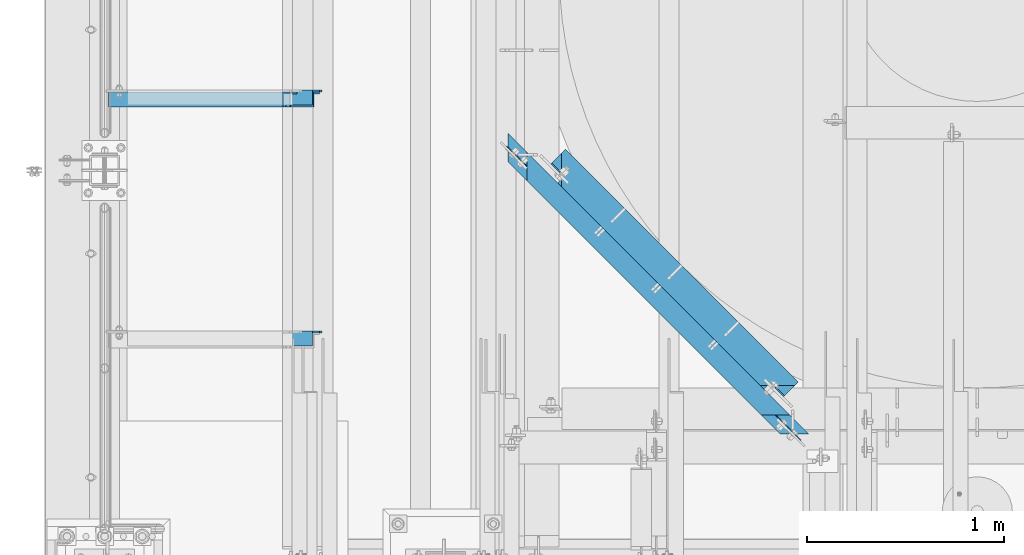
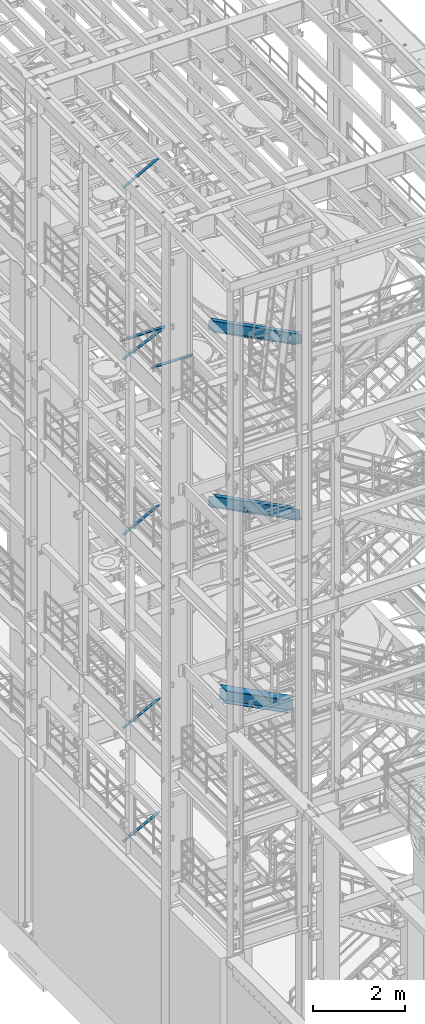
# One storey, part 971 of 1876: 5 beams, 5 members, 10 elements without a shape of their own.
"""IFC2X3 building model written with IfcOpenShell, lengths in millimetres."""

from ifc_helpers import new_model, si_unit, frame, origin_with_axes, place, context, subcontext, project, spatial, faceted_brep, material, type_object, element, aggregate, save


model = new_model("IFC2X3")

# Units and contexts
model_context = context("Model", 3, precision=1e-05, world=origin_with_axes())
body_context = subcontext(model_context, "Body", "Model", "MODEL_VIEW")
ifc_project = project(units=[si_unit("LENGTHUNIT", "METRE", prefix="MILLI"), si_unit("AREAUNIT", "SQUARE_METRE"), si_unit("VOLUMEUNIT", "CUBIC_METRE"), si_unit("MASSUNIT", "GRAM", prefix="KILO"), si_unit("TIMEUNIT", "SECOND"), si_unit("PLANEANGLEUNIT", "RADIAN"), si_unit("SOLIDANGLEUNIT", "STERADIAN"), si_unit("THERMODYNAMICTEMPERATUREUNIT", "DEGREE_CELSIUS"), si_unit("LUMINOUSINTENSITYUNIT", "LUMEN")], contexts=[model_context])

# Site, building, storey
site_placement = place(None, origin_with_axes())
site = spatial("IfcSite", under=ifc_project, at=site_placement, CompositionType="ELEMENT")
building_placement = place(site_placement, origin_with_axes())
building = spatial("IfcBuilding", under=site, at=building_placement, Name="Undefined", CompositionType="ELEMENT")
storey_placement = place(building_placement, origin_with_axes())
storey = spatial("IfcBuildingStorey", under=building, at=storey_placement, Name="Undefined", CompositionType="ELEMENT", Elevation=0.0)

# Assembly, member
assembly_1_placement = place(storey_placement, origin_with_axes())
assembly_1 = element("IfcElementAssembly", 1, at=assembly_1_placement, inside=storey, AssemblyPlace="NOTDEFINED", PredefinedType="RIGID_FRAME")
ifc_material_1 = material(Name="STEEL/A36")
member_type = type_object("IfcMemberType", Name="L3X3X3/8", PredefinedType="NOTDEFINED")
member_1_placement = place(assembly_1_placement, frame((15.9156353109856, -2181.225, 17440.5834930797), z_axis=(0.0, -1.0, 0.0), x_axis=(0.908569735485921, 0.0, 0.417733211223436)))
member_1 = element("IfcMember", 2, at=member_1_placement, type_object=member_type, material=ifc_material_1, ObjectType="L3X3X3/8", context=body_context, shape_type="Brep", body=[
    faceted_brep([(21.8406460853457, 38.0999999999894, -38.0999999999999), (21.8406460853457, 38.0999999999894, 38.0999999999999), (1162.88335939537, 38.0999999996566, 38.0999999999999), (1162.88335939537, 38.0999999996566, -38.0999999999999), (21.8406460853494, 28.5749999999916, 38.0999999999999), (1162.88335939538, 28.5749999996551, 38.0999999999999), (21.8406460853494, 28.5749999999916, -28.5749999999998), (1162.88335939538, 28.5749999996551, -28.5749999999998), (21.8406460853721, -38.1000000000022, -28.5749999999998), (1162.8833593954, -38.1000000003332, -28.5749999999998), (21.8406460853721, -38.1000000000022, -38.0999999999999), (1162.8833593954, -38.1000000003332, -38.0999999999999)], [[[0, 1, 2, 3]], [[1, 4, 5, 2]], [[4, 6, 7, 5]], [[6, 8, 9, 7]], [[8, 10, 11, 9]], [[10, 0, 3, 11]], [[5, 7, 9, 11, 3, 2]], [[10, 8, 6, 4, 1, 0]]]),
])
aggregate(assembly_1, [member_1])

assembly_2_placement = place(storey_placement, origin_with_axes())
assembly_2 = element("IfcElementAssembly", 3, at=assembly_2_placement, inside=storey, AssemblyPlace="NOTDEFINED", PredefinedType="RIGID_FRAME")
member_2_placement = place(assembly_2_placement, frame((17.8851909639217, -2181.225, 7599.05883178481), z_axis=(0.0, -1.0, 0.0), x_axis=(0.882970975303512, 0.0, 0.469427584161354)))
member_2 = element("IfcMember", 4, at=member_2_placement, type_object=member_type, material=ifc_material_1, ObjectType="L3X3X3/8", context=body_context, shape_type="Brep", body=[
    faceted_brep([(22.4738417769599, 38.1000000000004, -38.0999999999999), (22.4738417769599, 38.1000000000004, 38.0999999999999), (1061.87831940918, 38.0999999998248, 38.0999999999999), (1061.87831940918, 38.0999999998248, -38.0999999999999), (22.4738417769613, 28.5749999999998, 38.0999999999999), (1061.87831940918, 28.5749999998243, 38.0999999999999), (22.4738417769613, 28.5749999999998, -28.5749999999998), (1061.87831940918, 28.5749999998243, -28.5749999999998), (22.4738417769699, -38.100000000004, -28.5749999999998), (1061.87831940919, -38.1000000001804, -28.5749999999998), (22.4738417769699, -38.100000000004, -38.0999999999999), (1061.87831940919, -38.1000000001804, -38.0999999999999)], [[[0, 1, 2, 3]], [[1, 4, 5, 2]], [[4, 6, 7, 5]], [[6, 8, 9, 7]], [[8, 10, 11, 9]], [[10, 0, 3, 11]], [[5, 7, 9, 11, 3, 2]], [[10, 8, 6, 4, 1, 0]]]),
])
aggregate(assembly_2, [member_2])

assembly_3_placement = place(storey_placement, origin_with_axes())
assembly_3 = element("IfcElementAssembly", 5, at=assembly_3_placement, inside=storey, AssemblyPlace="NOTDEFINED", PredefinedType="RIGID_FRAME")
member_3_placement = place(assembly_3_placement, frame((17.8851909627118, -2181.225, 4576.45883178417), z_axis=(0.0, -1.0, 0.0), x_axis=(0.882970975303512, 0.0, 0.469427584161354)))
member_3 = element("IfcMember", 6, at=member_3_placement, type_object=member_type, material=ifc_material_1, ObjectType="L3X3X3/8", context=body_context, shape_type="Brep", body=[
    faceted_brep([(22.4738417769599, 38.1000000000004, -38.0999999999999), (22.4738417769599, 38.1000000000004, 38.0999999999999), (1061.87831940918, 38.0999999998248, 38.0999999999999), (1061.87831940918, 38.0999999998248, -38.0999999999999), (22.4738417769613, 28.5749999999998, 38.0999999999999), (1061.87831940918, 28.5749999998243, 38.0999999999999), (22.4738417769613, 28.5749999999998, -28.5749999999998), (1061.87831940918, 28.5749999998243, -28.5749999999998), (22.4738417769699, -38.100000000004, -28.5749999999998), (1061.87831940919, -38.1000000001804, -28.5749999999998), (22.4738417769699, -38.100000000004, -38.0999999999999), (1061.87831940919, -38.1000000001804, -38.0999999999999)], [[[0, 1, 2, 3]], [[1, 4, 5, 2]], [[4, 6, 7, 5]], [[6, 8, 9, 7]], [[8, 10, 11, 9]], [[10, 0, 3, 11]], [[5, 7, 9, 11, 3, 2]], [[10, 8, 6, 4, 1, 0]]]),
])
aggregate(assembly_3, [member_3])

assembly_4_placement = place(storey_placement, origin_with_axes())
assembly_4 = element("IfcElementAssembly", 7, at=assembly_4_placement, inside=storey, Name="BRACE", AssemblyPlace="NOTDEFINED", PredefinedType="RIGID_FRAME")
member_4_placement = place(assembly_4_placement, frame((18.2145803605003, -2181.225, 12755.4360034921), z_axis=(0.0, -1.0, 0.0), x_axis=(0.878320118391342, 0.0, 0.478072975213009)))
member_4 = element("IfcMember", 8, at=member_4_placement, type_object=member_type, material=ifc_material_1, Name="BRACE", ObjectType="L3X3X3/8", context=body_context, shape_type="Brep", body=[
    faceted_brep([(1042.67554503748, -38.1000000001168, -28.5749999999998), (1042.67554503748, -38.1000000001168, -38.0999999999999), (1042.67554503746, 38.0999999998312, -38.0999999999999), (1042.67554503746, 38.0999999998312, 38.0999999999999), (1042.67554503746, 28.5749999998388, 38.0999999999999), (1042.67554503746, 28.5749999998388, -28.5749999999998), (22.5928446582657, 28.5749999999789, 38.0999999999999), (22.5928446582657, 28.5749999999789, -28.5749999999998), (22.5928446582811, -38.0999999999749, -28.5749999999998), (22.5928446582811, -38.0999999999749, -38.0999999999999), (22.592844658262, 38.0999999999713, -38.0999999999999), (22.592844658262, 38.0999999999713, 38.0999999999999)], [[[0, 1, 2, 3, 4, 5]], [[5, 4, 6, 7]], [[0, 5, 7, 8]], [[1, 0, 8, 9]], [[2, 1, 9, 10]], [[3, 2, 10, 11]], [[4, 3, 11, 6]], [[10, 9, 8, 7, 6, 11]]]),
])
aggregate(assembly_4, [member_4])

assembly_5_placement = place(storey_placement, origin_with_axes())
assembly_5 = element("IfcElementAssembly", 9, at=assembly_5_placement, inside=storey, AssemblyPlace="NOTDEFINED", PredefinedType="RIGID_FRAME")
member_5_placement = place(assembly_5_placement, frame((18.2754879686868, -2181.225, 22001.0692535961), z_axis=(0.0, -1.0, 0.0), x_axis=(0.877448093107104, 0.0, 0.479671600058526)))
member_5 = element("IfcMember", 10, at=member_5_placement, type_object=member_type, material=ifc_material_1, ObjectType="L3X3X3/8", context=body_context, shape_type="Brep", body=[
    faceted_brep([(22.6152978728696, 38.0999999999985, -38.0999999999999), (22.6152978728696, 38.0999999999985, 38.0999999999999), (1025.78606203808, 38.1000000013628, 38.0999999999999), (1025.78606203808, 38.1000000013628, -38.0999999999999), (22.6152978728605, 28.5750000000044, 38.0999999999999), (1025.78606203807, 28.5750000013722, 38.0999999999999), (22.6152978728605, 28.5750000000044, -28.5749999999998), (1025.78606203807, 28.5750000013722, -28.5749999999998), (22.6152978728023, -38.0999999999367, -28.5749999999998), (1025.78606203801, -38.0999999985652, -28.5749999999998), (22.6152978728023, -38.0999999999367, -38.0999999999999), (1025.78606203801, -38.0999999985652, -38.0999999999999)], [[[0, 1, 2, 3]], [[1, 4, 5, 2]], [[4, 6, 7, 5]], [[6, 8, 9, 7]], [[8, 10, 11, 9]], [[10, 0, 3, 11]], [[5, 7, 9, 11, 3, 2]], [[10, 8, 6, 4, 1, 0]]]),
])
aggregate(assembly_5, [member_5])

# Assembly, beam
assembly_6_placement = place(storey_placement, origin_with_axes())
assembly_6 = element("IfcElementAssembly", 11, at=assembly_6_placement, inside=storey, Name="ANGLE", AssemblyPlace="NOTDEFINED", PredefinedType="RIGID_FRAME")
beam_type_1 = type_object("IfcBeamType", Name="L3X3X3/8", PredefinedType="NOTDEFINED")
beam_1_placement = place(assembly_6_placement, frame((-4.93498325010575e-08, -3390.9, 17945.1), z_axis=(0.0, -1.0, 0.0), x_axis=(1.0, 0.0, 0.0)))
beam_1 = element("IfcBeam", 12, at=beam_1_placement, type_object=beam_type_1, material=ifc_material_1, Name="ANGLE", ObjectType="L3X3X3/8", context=body_context, shape_type="Brep", body=[
    faceted_brep([(115.886999817316, 28.5750000000007, 38.0999999999999), (115.886999817316, 38.0999999999985, 38.0999999999999), (115.886998826692, 38.0999999999985, -38.0999999999999), (115.88699882669, 12.699999237062, -38.0999999999999), (115.886998950515, 12.699999237062, -28.5749999999998), (115.88699895052, 28.5750000000007, -28.5749999999998), (38.8937432114558, 12.699999237062, -38.0999999999999), (38.8937433352807, 12.699999237062, -28.5749999999998), (7.14374321145577, -19.050000762938, -38.0999999999999), (7.14374333528067, -19.050000762938, -28.5749999999998), (7.1437499954859, -38.0999999999985, -38.0999999999999), (7.1437499954859, -38.0999999999985, -28.5749999999998), (1101.72500281572, 15.8750003814712, -28.5749999999998), (1089.02500300646, 28.5750000000007, -28.5749999999998), (1052.51300101518, 28.5750000000007, -28.5749999999998), (1101.72500039161, -38.0999999999985, -28.5749999999998), (1101.72500281572, 3.17500152588036, -28.5749999999998), (1052.51300281541, 28.5750000000007, 38.0999999999999), (1052.5130028154, 38.0999999999985, 38.0999999999999), (1052.513000758, 38.0999999999985, -38.0999999999999), (1052.51300075801, 28.5750001907363, -38.0999999999999), (1089.02500274928, 28.5750001907363, -38.0999999999999), (1101.72500255855, 15.8750003814712, -38.0999999999999), (1101.72500255855, 3.17500152588036, -38.0999999999999), (1101.72500039161, -38.0999999999985, -38.0999999999999)], [[[0, 1, 2, 3, 4, 5]], [[4, 3, 6, 7]], [[7, 6, 8, 9]], [[8, 10, 11, 9]], [[12, 13, 14, 5, 4, 7, 9, 11, 15, 16]], [[0, 5, 14, 17]], [[1, 0, 17, 18]], [[2, 1, 18, 19]], [[17, 14, 20, 19, 18]], [[13, 21, 20, 14]], [[12, 22, 21, 13]], [[16, 23, 22, 12]], [[10, 8, 6, 3, 2, 19, 20, 21, 22, 23, 24]], [[11, 10, 24, 15]], [[23, 16, 15, 24]]]),
])
aggregate(assembly_6, [beam_1])

assembly_7_placement = place(storey_placement, origin_with_axes())
assembly_7 = element("IfcElementAssembly", 13, at=assembly_7_placement, inside=storey, Name="ANGLE", AssemblyPlace="NOTDEFINED", PredefinedType="RIGID_FRAME")
beam_2_placement = place(assembly_7_placement, frame((-4.93498325010575e-08, -2171.7, 17945.1), z_axis=(0.0, -1.0, 0.0), x_axis=(1.0, 0.0, 0.0)))
beam_2 = element("IfcBeam", 14, at=beam_2_placement, type_object=beam_type_1, material=ifc_material_1, Name="ANGLE", ObjectType="L3X3X3/8", context=body_context, shape_type="Brep", body=[
    faceted_brep([(115.886999817316, 28.5750000000007, 38.0999999999999), (115.886999817316, 38.0999999999985, 38.0999999999999), (115.886998826692, 38.0999999999985, -38.0999999999999), (115.88699882669, 12.699999237062, -38.0999999999999), (115.886998950515, 12.699999237062, -28.5749999999998), (115.88699895052, 28.5750000000007, -28.5749999999998), (38.8937432114558, 12.699999237062, -38.0999999999999), (38.8937433352807, 12.699999237062, -28.5749999999998), (7.14374321145577, -19.050000762938, -38.0999999999999), (7.14374333528067, -19.050000762938, -28.5749999999998), (7.1437499954859, -38.0999999999985, -38.0999999999999), (7.1437499954859, -38.0999999999985, -28.5749999999998), (1101.72500281572, 15.8750003814712, -28.5749999999998), (1089.02500300646, 28.5750000000007, -28.5749999999998), (1052.51300101518, 28.5750000000007, -28.5749999999998), (1101.72500039161, -38.0999999999985, -28.5749999999998), (1101.72500281572, 3.17500152588036, -28.5749999999998), (1052.51300281541, 28.5750000000007, 38.0999999999999), (1052.5130028154, 38.0999999999985, 38.0999999999999), (1052.513000758, 38.0999999999985, -38.0999999999999), (1052.51300075801, 28.5750001907363, -38.0999999999999), (1089.02500274928, 28.5750001907363, -38.0999999999999), (1101.72500255855, 15.8750003814712, -38.0999999999999), (1101.72500255855, 3.17500152588036, -38.0999999999999), (1101.72500039161, -38.0999999999985, -38.0999999999999)], [[[0, 1, 2, 3, 4, 5]], [[4, 3, 6, 7]], [[7, 6, 8, 9]], [[8, 10, 11, 9]], [[12, 13, 14, 5, 4, 7, 9, 11, 15, 16]], [[0, 5, 14, 17]], [[1, 0, 17, 18]], [[2, 1, 18, 19]], [[17, 14, 20, 19, 18]], [[13, 21, 20, 14]], [[12, 22, 21, 13]], [[16, 23, 22, 12]], [[10, 8, 6, 3, 2, 19, 20, 21, 22, 23, 24]], [[11, 10, 24, 15]], [[23, 16, 15, 24]]]),
])
aggregate(assembly_7, [beam_2])

assembly_8_placement = place(storey_placement, origin_with_axes())
assembly_8 = element("IfcElementAssembly", 15, at=assembly_8_placement, inside=storey, Name="BEAM", AssemblyPlace="NOTDEFINED", PredefinedType="RIGID_FRAME")
ifc_material_2 = material(Name="STEEL/A992")
beam_type_2 = type_object("IfcBeamType", Name="W12X16", PredefinedType="NOTDEFINED")
beam_3_placement = place(assembly_8_placement, frame((1935.71088494531, -2316.45279394776, 17830.8), z_axis=(0.0, 0.0, 1.0), x_axis=(0.707106781186547, -0.707106781186548, 0.0)))
beam_3 = element("IfcBeam", 16, at=beam_3_placement, type_object=beam_type_2, material=ifc_material_2, Name="BEAM", ObjectType="W12X16", context=body_context, shape_type="Brep", body=[
    faceted_brep([(2115.27622821424, -50.8000000000959, -152.400000000001), (2115.27622821424, -50.8000000000959, -146.049999999999), (276.775776753531, -50.80000000002, -146.049999999999), (276.775776753531, -50.80000000002, -152.400000000001), (2162.90122713662, -3.17500000008954, -146.049999999999), (229.150775675891, -3.17500000000996, -146.049999999999), (211.190263500312, -3.17500000000905, -131.762500000008), (204.840263356628, 3.17499999999222, -131.762500000008), (211.713453803021, 3.17499999999177, -132.729229922596), (218.063453946705, -3.17500000000973, -132.729229922596), (217.540263309576, 3.17499999999154, -135.482243823073), (223.89026345326, -3.17500000000973, -135.482243823073), (221.433612949082, 3.17499999999109, -139.602420291227), (227.783613092765, -3.17500000000996, -139.602420291227), (222.800775532225, 3.17499999999131, -144.462499809273), (229.150775675909, -3.17500000000996, -144.462499809273), (2169.25122699293, 3.17499999991128, -146.049999999999), (2216.87622591531, 50.7999999999172, -146.049999999999), (175.175774454565, 50.8000000000013, -146.049999999999), (222.800775532206, 3.17499999999154, -146.049999999999), (2216.87622591531, 50.7999999999172, -152.400000000001), (175.175774454565, 50.8000000000013, -152.400000000001), (2169.25122699299, 3.17499999991128, -144.46249980927), (2162.90122713668, -3.17500000008999, -144.46249980927), (2170.6183895452, 3.17499999991128, -139.602420291223), (2164.26838968888, -3.17500000008954, -139.602420291223), (2174.51173909661, 3.17499999991082, -135.482243823069), (2168.16173924029, -3.17500000008999, -135.482243823069), (2180.33854847132, 3.17499999991082, -132.729229922592), (2173.98854861501, -3.17500000009045, -132.729229922592), (2187.21173876219, 3.17499999991037, -131.762500000004), (2180.86173890588, -3.1750000000909, -131.762500000004), (2249.75442416533, 3.17500000041946, -131.762500000004), (2249.75442416532, -3.17499999958, -131.762500000004), (2249.75442416533, 3.17500000041946, 123.825000000001), (2249.75442416532, -3.17499999958, 123.825000000001), (2187.2117387629, 3.17499999991037, 123.825000000001), (2180.86173890659, -3.1750000000909, 123.825000000001), (2180.33854847203, 3.17499999991037, 124.791729922588), (2173.98854861571, -3.1750000000909, 124.791729922588), (2174.51173909732, 3.17499999991082, 127.544743823066), (2168.161739241, -3.17500000008999, 127.544743823066), (2170.61838954591, 3.17499999991128, 131.664920291219), (2164.26838968959, -3.17500000008999, 131.664920291219), (2169.2512269937, 3.17499999991128, 136.524999809266), (2162.90122713738, -3.17500000008954, 136.524999809266), (276.775776753639, -50.8000000000197, 152.400000000001), (276.775776753639, -50.8000000000197, 146.049999999999), (2115.27622821503, -50.8000000000959, 146.049999999999), (2115.27622821503, -50.8000000000959, 152.400000000001), (175.175774454672, 50.8000000000015, 152.400000000001), (2216.87622591609, 50.7999999999176, 152.400000000001), (175.175774454672, 50.8000000000015, 146.049999999999), (2216.87622591609, 50.7999999999176, 146.049999999999), (222.800775532313, 3.17499999999154, 146.049999999999), (2169.25122699372, 3.17499999991128, 146.049999999999), (2162.9012271374, -3.17500000008999, 146.049999999999), (229.150775675998, -3.17500000000973, 146.049999999999), (222.800775532253, 3.17499999999131, 136.524999809262), (229.150775675937, -3.17500000000973, 136.524999809262), (221.43361294911, 3.17499999999131, 131.664920291216), (227.783613092794, -3.17500000000973, 131.664920291216), (217.540263309605, 3.17499999999177, 127.544743823062), (223.890263453288, -3.1750000000095, 127.544743823062), (211.713453803049, 3.17499999999177, 124.791729922585), (218.063453946732, -3.17500000000928, 124.791729922585), (204.840263356657, 3.174999999992, 123.824999999997), (211.19026350034, -3.17500000000928, 123.824999999997), (142.297572892666, -3.17500000000632, 123.824999999997), (142.297572892666, -3.17500000000632, -131.762500000008), (142.297572892665, 3.17499999999472, -131.762500000008), (142.297572892665, 3.17499999999472, 123.824999999997)], [[[0, 1, 2, 3]], [[1, 4, 5, 2]], [[6, 7, 8, 9]], [[9, 8, 10, 11]], [[11, 10, 12, 13]], [[13, 12, 14, 15]], [[16, 17, 18, 19]], [[17, 20, 21, 18]], [[2, 5, 15, 14, 19, 18, 21, 3]], [[20, 0, 3, 21]], [[17, 16, 22, 23, 4, 1, 0, 20]], [[24, 25, 23, 22]], [[26, 27, 25, 24]], [[28, 29, 27, 26]], [[30, 31, 29, 28]], [[31, 30, 32, 33]], [[32, 34, 35, 33]], [[36, 37, 35, 34]], [[38, 39, 37, 36]], [[40, 41, 39, 38]], [[42, 43, 41, 40]], [[44, 45, 43, 42]], [[46, 47, 48, 49]], [[50, 46, 49, 51]], [[52, 50, 51, 53]], [[54, 52, 53, 55]], [[51, 49, 48, 56, 45, 44, 55, 53]], [[47, 57, 56, 48]], [[46, 50, 52, 54, 58, 59, 57, 47]], [[59, 58, 60, 61]], [[61, 60, 62, 63]], [[63, 62, 64, 65]], [[65, 64, 66, 67]], [[6, 9, 11, 13, 15, 5, 4, 23, 25, 27, 29, 31, 33, 35, 37, 39, 41, 43, 45, 56, 57, 59, 61, 63, 65, 67, 68, 69]], [[7, 6, 69, 70]], [[66, 64, 62, 60, 58, 54, 55, 44, 42, 40, 38, 36, 34, 32, 30, 28, 26, 24, 22, 16, 19, 14, 12, 10, 8, 7, 70, 71]], [[67, 66, 71, 68]], [[70, 69, 68, 71]]]),
])
aggregate(assembly_8, [beam_3])

assembly_9_placement = place(storey_placement, origin_with_axes())
assembly_9 = element("IfcElementAssembly", 17, at=assembly_9_placement, inside=storey, Name="BEAM", AssemblyPlace="NOTDEFINED", PredefinedType="RIGID_FRAME")
beam_4_placement = place(assembly_9_placement, frame((3303.29389435104, -3684.29114297626, 13157.2), z_axis=(0.0, 0.0, 1.0), x_axis=(-0.707106781186548, 0.707106781186547, 0.0)))
beam_4 = element("IfcBeam", 18, at=beam_4_placement, type_object=beam_type_2, material=ifc_material_2, Name="BEAM", ObjectType="W12X16", context=body_context, shape_type="Brep", body=[
    faceted_brep([(1696.0160685203, -50.7999999998278, 152.4), (1696.0160685203, -50.7999999998278, 146.049999999999), (1648.3910821254, -3.17499999983943, 146.049999999999), (1648.3910821254, -3.17499999983943, 128.587499809264), (1642.04108393941, 3.17500000015934, 128.587499809264), (1642.04108393941, 3.17500000015934, 146.049999999999), (1594.41609754451, 50.8000000001473, 146.049999999999), (1594.41609754451, 50.8000000001473, 152.4), (1649.75824449779, -3.1749999998392, 123.727420291218), (1643.40824631181, 3.17500000015912, 123.727420291218), (1653.65159353714, -3.17499999983875, 119.607243823064), (1647.30159535115, 3.17500000015934, 119.607243823064), (1659.4784021455, -3.17499999983852, 116.854229922586), (1653.12840395951, 3.1750000001598, 116.854229922586), (1666.35159153239, -3.17499999983784, 115.887499999999), (1660.0015933464, 3.17500000016094, 115.887499999999), (1786.46249810805, -3.17499999982624, 115.887499999999), (1780.11249992206, 3.17500000017253, 115.887499999999), (-82.0778965322579, 50.7999999999847, 152.4), (-82.0778965322579, 50.7999999999847, 146.049999999999), (-129.702910137345, 3.17499999998699, 146.049999999999), (-129.702910137345, 3.17499999998699, 128.587499809264), (-136.052911951358, -3.17500000001246, 128.587499809264), (-136.052911951358, -3.17500000001246, 146.049999999999), (-183.677925556445, -50.8000000000102, 146.049999999999), (-183.677925556445, -50.8000000000102, 152.4), (-131.0700729003, 3.17499999998699, 123.727420291218), (-137.420074714312, -3.17500000001291, 123.727420291218), (-134.963423051866, 3.17499999998699, 119.607243823064), (-141.313424865878, -3.17500000001291, 119.607243823064), (-140.790233324775, 3.17499999998608, 116.854229922586), (-147.140235138787, -3.17500000001382, 116.854229922586), (-147.663424675142, 3.17499999998518, 115.887499999999), (-154.013426489153, -3.17500000001473, 115.887499999999), (-267.774365563642, 3.17499999997335, 115.887499999999), (-274.124367377653, -3.17500000002656, 115.887499999999), (-267.774365563642, 3.17499999997335, -146.049999999999), (-220.149351958555, 50.7999999999711, -146.049999999999), (-220.149351958555, 50.7999999999711, -152.4), (-321.749380982741, -50.8000000000243, -152.4), (-321.749380982741, -50.8000000000243, -146.049999999999), (-274.124367377653, -3.17500000002656, -146.049999999999), (1780.11249992206, 3.17500000017253, -146.049999999999), (1732.48751352716, 50.8000000001609, -146.049999999999), (1732.48751352716, 50.8000000001609, -152.4), (1834.08748450295, -50.7999999998146, -152.4), (1834.08748450295, -50.7999999998146, -146.049999999999), (1786.46249810805, -3.17499999982624, -146.049999999999)], [[[0, 1, 2, 3, 4, 5, 6, 7]], [[8, 9, 4, 3]], [[10, 11, 9, 8]], [[12, 13, 11, 10]], [[14, 15, 13, 12]], [[16, 17, 15, 14]], [[18, 19, 20, 21, 22, 23, 24, 25]], [[26, 27, 22, 21]], [[28, 29, 27, 26]], [[30, 31, 29, 28]], [[32, 33, 31, 30]], [[34, 35, 33, 32]], [[36, 37, 38, 39, 40, 41, 35, 34]], [[37, 36, 42, 43]], [[38, 37, 43, 44]], [[39, 38, 44, 45]], [[40, 39, 45, 46]], [[41, 40, 46, 47]], [[12, 10, 8, 3, 2, 23, 22, 27, 29, 31, 33, 35, 41, 47, 16, 14]], [[24, 23, 2, 1]], [[25, 24, 1, 0]], [[18, 25, 0, 7]], [[19, 18, 7, 6]], [[20, 19, 6, 5]], [[42, 36, 34, 32, 30, 28, 26, 21, 20, 5, 4, 9, 11, 13, 15, 17]], [[47, 46, 45, 44, 43, 42, 17, 16]]]),
])
aggregate(assembly_9, [beam_4])

assembly_10_placement = place(storey_placement, origin_with_axes())
assembly_10 = element("IfcElementAssembly", 19, at=assembly_10_placement, inside=storey, Name="BEAM", AssemblyPlace="NOTDEFINED", PredefinedType="RIGID_FRAME")
beam_type_3 = type_object("IfcBeamType", Name="W14X48", PredefinedType="NOTDEFINED")
beam_5_placement = place(assembly_10_placement, frame((2197.1, -2440.04975264343, 7978.775), z_axis=(0.0, 0.0, 1.0), x_axis=(0.707106781186547, -0.707106781186548, 0.0)))
beam_5 = element("IfcBeam", 20, at=beam_5_placement, type_object=beam_type_3, material=ifc_material_2, Name="BEAM", ObjectType="W14X48", context=body_context, shape_type="Brep", body=[
    faceted_brep([(90.9649917881488, 101.6, 158.75), (90.9649917881488, 101.6, 174.625), (1758.88006185463, 101.600000000262, 174.625), (1758.88006185463, 101.600000000262, 158.75), (90.9649917881488, 75.1697394882857, 158.75), (90.9649917881488, 75.1697394882857, 174.625), (90.9649917881488, 101.6, -158.75), (90.9649929080101, 3.96875000000273, -158.75), (1758.88006185463, 3.96875000027526, -158.75), (1758.88006185463, 101.600000000262, -158.75), (90.9649917881488, 101.6, -174.625), (1758.88006185463, 101.600000000262, -174.625), (1758.88006185463, -3.96874999972337, -158.75), (1664.18754228063, -3.96874999973838, -158.75), (1660.2185988186, -3.96874999973929, -158.75), (1660.2185988186, -3.96870604052523, -174.625), (1664.18754227809, -3.96870597036227, -174.625), (1758.88006185463, -3.96870429637679, -174.625), (1660.2186005445, -101.599999999726, -158.75), (1660.2186005445, -101.599999999726, -174.625), (185.657550466564, -3.96874999997075, -158.75), (185.657373667258, -101.599999999957, -158.75), (185.657373667258, -101.599999999957, -174.625), (90.9649917881488, -3.96793732113392, -174.625), (185.657550468893, -3.96810879993049, -174.625), (90.9649929080092, -3.96875, -158.75), (90.9649917881488, -3.96874999998576, -149.233551893037), (90.9649917881488, -3.96874999998576, -92.8150055768701), (90.9649917881488, -3.96874999998576, 137.265008229234), (90.9649929080092, -3.96875, 142.875), (90.9649929080101, 3.96875000000273, 142.875), (152.142945789183, -3.96874999997598, 142.875), (144.205448449586, 3.96875000002152, 142.875), (159.016135005973, -3.96874999997507, 143.841729922588), (151.078637666375, 3.96875000002265, 143.841729922588), (164.842943470122, -3.96874999997394, 146.594743823066), (156.905446130525, 3.96875000002356, 146.594743823066), (168.736292413114, -3.96874999997326, 150.71492029122), (160.798795073517, 3.96875000002424, 150.71492029122), (170.103454751674, -3.96874999997326, 155.574999809265), (162.165957412077, 3.96875000002447, 155.574999809265), (267.73467202872, -101.599999999944, 174.625), (162.165957412077, 3.9687500000247, 158.75), (170.103454751674, -3.96874999997326, 158.75), (267.73467202872, -101.599999999944, 158.75), (1679.74151930923, -3.9687499997361, 158.75), (1582.11023658629, -101.599999999738, 158.75), (1582.11023658629, -101.599999999738, 174.625), (1758.88006185463, 75.1697660209185, 174.625), (1758.88006185463, 75.1697660209185, 158.75), (1687.67902196963, 3.96875000026344, 158.75), (1679.74151930923, -3.9687499997361, 155.574999809265), (1687.67902196963, 3.96875000026344, 155.574999809265), (1681.10868210602, -3.96874999973565, 150.71492029122), (1689.04618476642, 3.96875000026435, 150.71492029122), (1685.00203235394, -3.96874999973565, 146.594743823066), (1692.93953501434, 3.96875000026435, 146.594743823066), (1690.82884277105, -3.96874999973429, 143.841729922588), (1698.76634543146, 3.96875000026526, 143.841729922588), (1705.63953695193, 3.96875000026662, 142.875), (1758.88006185463, 3.96875000027526, 142.875), (1758.88006185463, -3.96874999972337, 137.264997439641), (1758.88006185463, -3.96874999972337, 25.0999999999995), (1758.88006185463, -3.96874999972337, -92.8149893924801), (1758.88006185463, -3.96874999972337, -149.232908869742), (1758.88006185463, -3.96874999972337, 142.875), (1697.70203429152, -3.96874999973338, 142.875)], [[[0, 1, 2, 3]], [[1, 0, 4, 5]], [[6, 7, 8, 9]], [[10, 6, 9, 11]], [[12, 13, 14, 15, 16, 17]], [[18, 19, 15, 14]], [[18, 14, 20, 21]], [[19, 18, 21, 22]], [[23, 10, 11, 17, 16, 15, 19, 22, 24]], [[21, 20, 24, 22]], [[25, 23, 24, 20]], [[26, 27, 28, 29, 30, 7, 6, 10, 23, 25]], [[31, 32, 30, 29]], [[33, 34, 32, 31]], [[35, 36, 34, 33]], [[37, 38, 36, 35]], [[39, 40, 38, 37]], [[41, 5, 4, 42, 40, 39, 43, 44]], [[44, 43, 45, 46]], [[41, 44, 46, 47]], [[2, 1, 5, 41, 47, 48]], [[3, 2, 48, 49]], [[42, 4, 0, 3, 49, 50]], [[48, 47, 46, 45, 51, 52, 50, 49]], [[52, 51, 53, 54]], [[54, 53, 55, 56]], [[56, 55, 57, 58]], [[8, 7, 30, 32, 34, 36, 38, 40, 42, 50, 52, 54, 56, 58, 59, 60]], [[61, 62, 63, 64, 12, 17, 11, 9, 8, 60, 65]], [[57, 55, 53, 51, 45, 43, 39, 37, 35, 33, 31, 29, 28, 27, 26, 25, 20, 14, 13, 12, 64, 63, 62, 61, 65, 66]], [[58, 57, 66, 59]], [[65, 60, 59, 66]]]),
])
aggregate(assembly_10, [beam_5])

save(model, "model.ifc")
